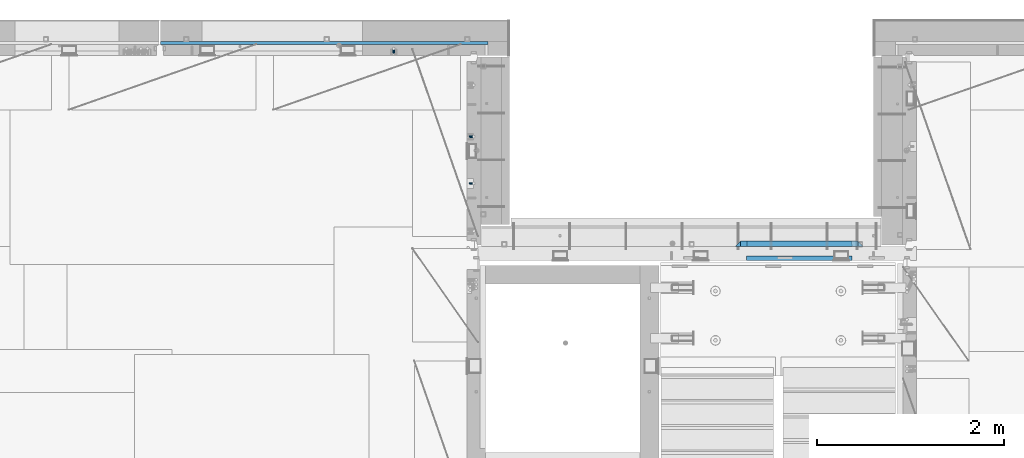
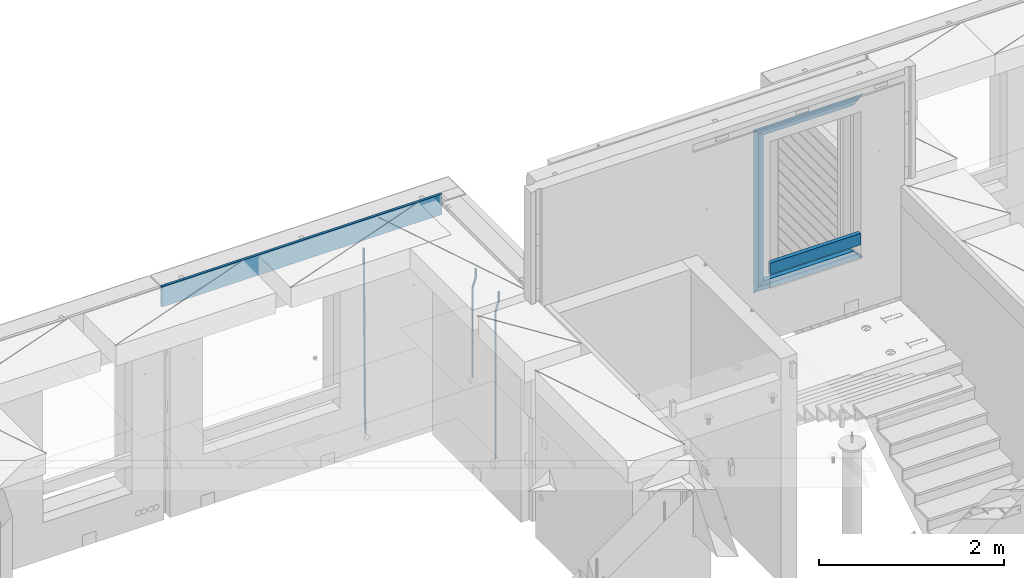
# One storey, part 118 of 341: 11 beams, 3 elements without a shape of their own.
"""IFC2X3 building model written with IfcOpenShell, lengths in millimetres."""

from ifc_helpers import new_model, si_unit, frame, origin_with_axes, place, context, subcontext, project, spatial, faceted_brep, material, type_object, element, aggregate, save


model = new_model("IFC2X3")

# Units and contexts
model_context = context("Model", 3, precision=1e-05, world=origin_with_axes())
body_context = subcontext(model_context, "Body", "Model", "MODEL_VIEW")
ifc_project = project(units=[si_unit("LENGTHUNIT", "METRE", prefix="MILLI"), si_unit("AREAUNIT", "SQUARE_METRE"), si_unit("VOLUMEUNIT", "CUBIC_METRE"), si_unit("MASSUNIT", "GRAM", prefix="KILO"), si_unit("TIMEUNIT", "SECOND"), si_unit("PLANEANGLEUNIT", "RADIAN"), si_unit("SOLIDANGLEUNIT", "STERADIAN"), si_unit("THERMODYNAMICTEMPERATUREUNIT", "DEGREE_CELSIUS"), si_unit("LUMINOUSINTENSITYUNIT", "LUMEN")], contexts=[model_context])

# Site, building, storey
site_placement = place(None, origin_with_axes())
site = spatial("IfcSite", under=ifc_project, at=site_placement, CompositionType="ELEMENT")
building_placement = place(site_placement, origin_with_axes())
building = spatial("IfcBuilding", under=site, at=building_placement, CompositionType="ELEMENT")
storey_placement = place(building_placement, origin_with_axes())
storey = spatial("IfcBuildingStorey", under=building, at=storey_placement, Name="5", CompositionType="ELEMENT", Elevation=0.0)

# Assembly, beam
assembly_1_placement = place(storey_placement, origin_with_axes())
assembly_1 = element("IfcElementAssembly", 1, at=assembly_1_placement, inside=storey, AssemblyPlace="NOTDEFINED", PredefinedType="REINFORCEMENT_UNIT")
ifc_material_1 = material()
beam_type_1 = type_object("IfcBeamType", Name="D20", PredefinedType="NOTDEFINED")
beam_1_placement = place(assembly_1_placement, frame((16830.0000000039, 22654.999995444, 93990.0), z_axis=(-0.000205762999925498, 0.999642804629538, -0.0267249099901004), x_axis=(4.30000201928125e-08, 0.0267249099948059, 0.999642825806181)))
beam_1 = element("IfcBeam", 2, at=beam_1_placement, type_object=beam_type_1, material=ifc_material_1, Name="JM20", ObjectType="D20", context=body_context, shape_type="Brep", body=[
    faceted_brep([(0.0, -10.0, 0.0), (-4.19531716033816e-08, -7.07106781186667, -7.07106781187031), (60.4266690400545, -7.0710677960451, -7.07106780570757), (60.4266690441291, -9.99999998418934, 6.15546014159918e-09), (0.0, 0.0, -10.0), (60.426669036824, 1.58106558956206e-08, -9.99999999384454), (4.196772351861e-08, 7.07106781186303, -7.07106781186667), (60.4266690363438, 7.07106782768096, -7.07106780570757), (0.0, 10.0, 0.0), (60.4266690388904, 10.0000000158179, 6.15182216279209e-09), (4.196772351861e-08, 7.07106781185939, 7.07106781185939), (60.4266690429649, 7.07106782768096, 7.07106781802577), (0.0, 0.0, 10.0), (60.4266690461809, 1.58179318532348e-08, 10.0000000061555), (-4.19531716033816e-08, -7.07106781187031, 7.07106781185939), (60.4266690466611, -7.07106779605238, 7.07106781802213), (61.0378400410118, -7.07106779588503, -7.07106780564936), (60.991799419251, -9.99999998403655, 6.21366780251265e-09), (61.0569027789461, 1.5985278878361e-08, -9.99999999378269), (61.0378209396877, 7.07106782784831, -7.07106780564936), (60.9917724058905, 10.0000000159635, 6.21366780251265e-09), (60.9457317841297, 7.07106782781193, 7.0710678180767), (60.9266690461809, 1.59488990902901e-08, 10.0000000062028), (60.9457508854539, -7.07106779591413, 7.0710678180767), (61.6489592143771, -7.07106614513759, -7.06310863441468), (61.5568818710308, -9.9999984576425, 0.00735959856683621), (61.6870830769039, 1.71821739058942e-06, -9.99179257185824), (61.6489210170112, 7.07106947854481, -7.06310888312146), (61.556827851804, 10.0000015422847, 0.00735924683976918), (61.4647505084577, 7.07106922979438, 7.07782747982128), (61.4266266459163, 1.36643211590126e-06, 10.0065114172685), (61.464788705809, -7.07106639389531, 7.07782772852806), (176.543135720174, -7.07075579406956, -5.56673531796696), (176.451058376813, -9.99968810657447, 1.50373291501455), (176.581259582701, 0.000312069292704109, -8.49541925541052), (176.543097522794, 7.07137982961285, -5.56673556667374), (176.451004357587, 10.00031189336, 1.50373256329476), (176.35892701424, 7.07137958085514, 8.57420079627263), (176.320803151699, 0.000311717507429421, 11.5028847337162), (176.358965211621, -7.07075604281999, 8.57420104497578), (177.098753836006, -7.07075429323595, -5.55949898843028), (176.98362511232, -9.99968666800123, 1.510669025065), (177.146421932586, 0.000313595905026887, -8.48805862247536), (177.098706077581, 7.07138133041735, -5.55949936166144), (176.983557571715, 10.0003133318824, 1.51066849724157), (176.868428848029, 7.07138095712435, 8.58083651073321), (176.820760751449, 0.000313067976094317, 11.5093961447819), (176.868476606425, -7.07075466652896, 8.58083688396073), (177.654312950661, -7.07075204110879, -5.54863964998367), (177.516135294456, -9.99968450931192, 1.52107783331303), (177.711524267797, 0.000315886711177882, -8.47701274570863), (177.654255632195, 7.07138358250813, -5.54864021007961), (177.516054233929, 10.0003154905207, 1.5210770412159), (177.377876577739, 7.0713830223176, 8.59079452451624), (177.320665260588, 0.000315094497636892, 11.5191676202448), (177.377933896176, -7.07075260129932, 8.59079508461218), (299.436796249574, -7.07025836271714, -3.1681962331204), (299.298618593355, -9.99919083092027, 3.90152125031091), (299.494007566798, 0.000809565110102994, -6.09656932889993), (299.436738931283, 7.07187726089978, -3.16819679320906), (299.298537533061, 10.0008091689197, 3.90152045822106), (299.160359876842, 7.07187670072017, 10.9712379416487), (299.103148559603, 0.000808772889286047, 13.8996110374392), (299.160417195119, -7.07025892290039, 10.9712385017483), (299.98743051647, -7.07025613056248, -3.15743315966392), (299.971788958996, -9.99918809853989, 3.91467979818117), (299.993912075952, 0.000811591617093654, -6.08679785393178), (299.987423933868, 7.07187949325817, -3.1574327280432), (299.971753863239, 10.0008119014747, 3.91467990454839), (299.95611230444, 7.07187992653053, 10.9867922621015), (299.949630744944, 0.000812204350950196, 13.9161569563694), (299.956118887014, -7.07025569729012, 10.9867918304735), (300.538107039494, -7.07025785017686, -3.16575821840888), (300.644985195438, -9.99919020432935, 3.90450175465594), (300.493854948218, 0.000810030429420294, -6.09435592770024), (300.538151196495, 7.071877773491, -3.16575855385963), (300.645047642858, 10.0008097955724, 3.90450128024895), (300.751925798773, 7.07187744142357, 10.9747612533101), (300.796177890064, 0.000809560813650023, 13.9033589625978), (300.751881641787, -7.07025818224065, 10.9747615887682), (2293.36490490142, -7.07648090940347, -33.2930642912361), (2293.47178305736, -10.0054132635523, -26.2228043181785), (2293.32065281013, -0.00541302880083094, -36.2216620005347), (2293.36494905842, 7.06565471425711, -33.2930646266868), (2293.47184550477, 9.99458673634581, -26.2228047925819), (2293.57872366071, 7.06565438219332, -19.1525448195243), (2293.62297575199, -0.00541349841296324, -16.2239471102366), (2293.57867950371, -7.0764812414709, -19.1525444840736), (2294.0658245362, -7.07648309818615, -33.3036607065333), (2294.05312277409, -10.0054150789219, -26.2315929392535), (2294.10928714235, -0.00541549149056664, -36.2335844756526), (2294.15805078732, 7.06565223761572, -33.3050546393533), (2294.18355038921, 9.99458451388637, -26.2335642579346), (2294.17084862708, 7.06565253314329, -19.1614964906439), (2294.12738602093, -0.00541507354500936, -16.2315727215355), (2294.07862237596, -7.07648280265857, -19.1601025578348), (2294.76670261032, -7.08562269121467, -33.294332712383), (2294.63442802057, -10.0129954178956, -26.2238563411993), (2294.89787471293, -0.0156988342423574, -36.2230891548279), (2294.95110548967, 7.05531064255774, -33.2944998654275), (2294.89521307347, 9.98530428734011, -26.2240927312887), (2294.76293848372, 7.0579315606592, -19.1536163601049), (2294.63176638114, -0.0119922963167483, -16.2248599176673), (2294.57853560438, -7.08300177311321, -19.1534492070678), (2316.52657204497, -7.36937582653991, -33.0047303660212), (2316.39429745522, -10.2967485532172, -25.9342539948302), (2316.65774414754, -0.299451969567599, -35.9334868084661), (2316.7109749243, 6.7715575072325, -33.0048975190657), (2316.65508250811, 9.70155115201487, -25.9344903849269), (2316.52280791836, 6.7741784253376, -18.8640140137468), (2316.39163581574, -0.295745431634714, -15.9352575713092), (2316.33840503903, -7.36675490843481, -18.863846860706), (2317.16202064224, -7.37766220584308, -32.9962731735213), (2317.05438744847, -10.3053562613532, -25.9254688497131), (2317.23607125619, -0.306993473008333, -35.925789846493), (2317.23316144495, 6.76474808850253, -32.9979477328052), (2317.15499573652, 9.6950321815566, -25.9278370341635), (2317.04736254275, 6.7673381260538, -18.8570327103698), (2316.97331192881, -0.303330606784584, -15.9275160373909), (2316.97622174003, -7.37507216829545, -18.8553581510787), (2317.79752306276, -7.37578610372293, -32.9880110666527), (2317.71453320107, -10.3033876998124, -25.9168792378296), (2317.81444760226, -0.305295583297266, -35.918287695793), (2317.75539265381, 6.76628640723357, -32.9911928173897), (2317.65495180529, 9.69652304524061, -25.9213789128698), (2317.5719619436, 6.76892144914746, -18.8502470840467), (2317.55503740412, -0.301569071270933, -15.9199704549137), (2317.61409235255, -7.3731510618054, -18.847065333317), (2417.8183084176, -7.07752398473531, -31.6906369377139), (2417.73531855589, -10.0051255808248, -24.6195051088798), (2417.83523295709, -0.007033464313281, -34.6209135668432), (2417.77617800863, 7.06454852621755, -31.6938186884508), (2417.67573716014, 9.99478516423187, -24.6240047839383), (2417.59274729842, 7.06718356813872, -17.5528729551006), (2417.57582275895, -0.00330695228694822, -14.6225963259749), (2417.6348777074, -7.07488894281778, -17.5496912043673)], [[[0, 1, 2, 3]], [[1, 4, 5, 2]], [[4, 6, 7, 5]], [[6, 8, 9, 7]], [[8, 10, 11, 9]], [[10, 12, 13, 11]], [[12, 14, 15, 13]], [[14, 0, 3, 15]], [[14, 12, 10, 8, 6, 4, 1, 0]], [[3, 2, 16, 17]], [[2, 5, 18, 16]], [[5, 7, 19, 18]], [[7, 9, 20, 19]], [[9, 11, 21, 20]], [[11, 13, 22, 21]], [[13, 15, 23, 22]], [[15, 3, 17, 23]], [[17, 16, 24, 25]], [[16, 18, 26, 24]], [[18, 19, 27, 26]], [[19, 20, 28, 27]], [[20, 21, 29, 28]], [[21, 22, 30, 29]], [[22, 23, 31, 30]], [[23, 17, 25, 31]], [[25, 24, 32, 33]], [[24, 26, 34, 32]], [[26, 27, 35, 34]], [[27, 28, 36, 35]], [[28, 29, 37, 36]], [[29, 30, 38, 37]], [[30, 31, 39, 38]], [[31, 25, 33, 39]], [[33, 32, 40, 41]], [[32, 34, 42, 40]], [[34, 35, 43, 42]], [[35, 36, 44, 43]], [[36, 37, 45, 44]], [[37, 38, 46, 45]], [[38, 39, 47, 46]], [[39, 33, 41, 47]], [[41, 40, 48, 49]], [[40, 42, 50, 48]], [[42, 43, 51, 50]], [[43, 44, 52, 51]], [[44, 45, 53, 52]], [[45, 46, 54, 53]], [[46, 47, 55, 54]], [[47, 41, 49, 55]], [[49, 48, 56, 57]], [[48, 50, 58, 56]], [[50, 51, 59, 58]], [[51, 52, 60, 59]], [[52, 53, 61, 60]], [[53, 54, 62, 61]], [[54, 55, 63, 62]], [[55, 49, 57, 63]], [[57, 56, 64, 65]], [[56, 58, 66, 64]], [[58, 59, 67, 66]], [[59, 60, 68, 67]], [[60, 61, 69, 68]], [[61, 62, 70, 69]], [[62, 63, 71, 70]], [[63, 57, 65, 71]], [[65, 64, 72, 73]], [[64, 66, 74, 72]], [[66, 67, 75, 74]], [[67, 68, 76, 75]], [[68, 69, 77, 76]], [[69, 70, 78, 77]], [[70, 71, 79, 78]], [[71, 65, 73, 79]], [[73, 72, 80, 81]], [[72, 74, 82, 80]], [[74, 75, 83, 82]], [[75, 76, 84, 83]], [[76, 77, 85, 84]], [[77, 78, 86, 85]], [[78, 79, 87, 86]], [[79, 73, 81, 87]], [[81, 80, 88, 89]], [[80, 82, 90, 88]], [[82, 83, 91, 90]], [[83, 84, 92, 91]], [[84, 85, 93, 92]], [[85, 86, 94, 93]], [[86, 87, 95, 94]], [[87, 81, 89, 95]], [[89, 88, 96, 97]], [[88, 90, 98, 96]], [[90, 91, 99, 98]], [[91, 92, 100, 99]], [[92, 93, 101, 100]], [[93, 94, 102, 101]], [[94, 95, 103, 102]], [[95, 89, 97, 103]], [[97, 96, 104, 105]], [[96, 98, 106, 104]], [[98, 99, 107, 106]], [[99, 100, 108, 107]], [[100, 101, 109, 108]], [[101, 102, 110, 109]], [[102, 103, 111, 110]], [[103, 97, 105, 111]], [[105, 104, 112, 113]], [[104, 106, 114, 112]], [[106, 107, 115, 114]], [[107, 108, 116, 115]], [[108, 109, 117, 116]], [[109, 110, 118, 117]], [[110, 111, 119, 118]], [[111, 105, 113, 119]], [[113, 112, 120, 121]], [[112, 114, 122, 120]], [[114, 115, 123, 122]], [[115, 116, 124, 123]], [[116, 117, 125, 124]], [[117, 118, 126, 125]], [[118, 119, 127, 126]], [[119, 113, 121, 127]], [[121, 120, 128, 129]], [[120, 122, 130, 128]], [[122, 123, 131, 130]], [[123, 124, 132, 131]], [[124, 125, 133, 132]], [[125, 126, 134, 133]], [[126, 127, 135, 134]], [[127, 121, 129, 135]], [[130, 131, 132, 133, 134, 135, 129, 128]]]),
])

# Assembly, beams
assembly_2_placement = place(storey_placement, origin_with_axes())
assembly_2 = element("IfcElementAssembly", 3, at=assembly_2_placement, inside=storey, AssemblyPlace="NOTDEFINED", PredefinedType="REINFORCEMENT_UNIT")
beam_2_placement = place(assembly_2_placement, frame((17685.0, 21755.0073333522, 96407.5), z_axis=(-0.999999913638316, 0.000415599999849952, 0.0), x_axis=(0.0, 0.0, -1.0)))
beam_2 = element("IfcBeam", 4, at=beam_2_placement, type_object=beam_type_1, material=ifc_material_1, Name="JM20", ObjectType="D20", context=body_context, shape_type="Brep", body=[
    faceted_brep([(0.0, -10.0, 0.0), (-4.19531716033816e-08, -7.07106781186667, -7.07106781187031), (113.248091332178, -7.0710684840451, -7.0710678117357), (113.248091314759, -10.0000006713562, -2.51020537689328e-10), (0.0, 0.0, -10.0), (113.248091374131, -6.72178430249915e-07, -9.99999999986903), (4.196772351861e-08, 7.07106781186303, -7.07106781186667), (113.248091416113, 7.07106713968824, -7.07106781173934), (0.0, 10.0, 0.0), (113.248091433488, 9.99999932782521, 1.30967237055302e-10), (4.196772351861e-08, 7.07106781185939, 7.07106781185939), (113.248091416113, 7.0710671396846, 7.071067811994), (0.0, 0.0, 10.0), (113.248091374131, -6.72174792271107e-07, 10.0000000001273), (-4.19531716033816e-08, -7.07106781187031, 7.07106781185939), (113.248091332178, -7.0710684840451, 7.071067811994), (130.699843527167, -7.06993249763036, -4.33745683788584), (128.538066582521, -9.99900540317321, 2.39499413731755), (131.594536475241, 0.00119355250353692, -7.12624594330919), (130.698046432328, 7.07220300913468, -4.33773834422391), (128.535525107087, 10.0009944322555, 2.39459602660281), (126.373748162892, 7.07192152754578, 9.1270470011732), (125.479055214906, 0.000795477419160306, 11.9158361066184), (126.37554525779, -7.07021397921199, 9.12732850753673), (240.336258550378, -7.05529970173666, 30.8729495437874), (238.174481606227, -9.98437260450009, 37.6054005176375), (241.230951498423, 0.0158263482953771, 28.0841604381058), (240.334461455612, 7.0868358050102, 30.8726680369582), (238.171940130502, 10.0156272283348, 37.6050024077231), (236.010163186409, 7.08655432384694, 44.3374533824244), (235.115470238379, 0.0154282738185429, 47.1262424881097), (236.011960281176, -7.05558118289991, 44.3377348892536), (253.461915329972, -7.05444528127919, 32.9289287376414), (253.46191532613, -9.98337746617108, 39.9999965521893), (253.461915339081, 0.0166225284556276, 29.9999965443676), (253.461915348205, 7.08769034247234, 32.9289287273205), (253.461915352003, 10.0166225357716, 39.9999965370152), (253.461915348293, 7.08769035281148, 47.0710643509774), (253.461915339183, 0.0166225430875784, 49.999996544273), (253.46191533003, -7.05444527093641, 47.0710643613093), (1417.49999998364, -7.05444797759628, 32.9289287358552), (1417.49999997689, -9.98338016170965, 39.9999965493844), (1417.49999999996, 0.0166198326005542, 29.9999965436982), (1417.50000001628, 7.08768764613342, 32.9289287278079), (1417.50000002306, 10.0166198382904, 39.9999965380084), (1417.5000000163, 7.08768765417699, 47.0710643515376), (1417.49999999999, 0.0166198439801519, 49.9999965436946), (1417.49999998366, -7.05444796955271, 47.0710643595849)], [[[0, 1, 2, 3]], [[1, 4, 5, 2]], [[4, 6, 7, 5]], [[6, 8, 9, 7]], [[8, 10, 11, 9]], [[10, 12, 13, 11]], [[12, 14, 15, 13]], [[14, 0, 3, 15]], [[14, 12, 10, 8, 6, 4, 1, 0]], [[3, 2, 16, 17]], [[2, 5, 18, 16]], [[5, 7, 19, 18]], [[7, 9, 20, 19]], [[9, 11, 21, 20]], [[11, 13, 22, 21]], [[13, 15, 23, 22]], [[15, 3, 17, 23]], [[17, 16, 24, 25]], [[16, 18, 26, 24]], [[18, 19, 27, 26]], [[19, 20, 28, 27]], [[20, 21, 29, 28]], [[21, 22, 30, 29]], [[22, 23, 31, 30]], [[23, 17, 25, 31]], [[25, 24, 32, 33]], [[24, 26, 34, 32]], [[26, 27, 35, 34]], [[27, 28, 36, 35]], [[28, 29, 37, 36]], [[29, 30, 38, 37]], [[30, 31, 39, 38]], [[31, 25, 33, 39]], [[33, 32, 40, 41]], [[32, 34, 42, 40]], [[34, 35, 43, 42]], [[35, 36, 44, 43]], [[36, 37, 45, 44]], [[37, 38, 46, 45]], [[38, 39, 47, 46]], [[39, 33, 41, 47]], [[42, 43, 44, 45, 46, 47, 41, 40]]]),
])
beam_type_2 = type_object("IfcBeamType", Name="D25", PredefinedType="NOTDEFINED")
beam_3_placement = place(assembly_2_placement, frame((17685.0, 21255.0073333522, 96407.5), z_axis=(-0.999999913638316, 0.000415599999849952, 0.0), x_axis=(0.0, 0.0, -1.0)))
beam_3 = element("IfcBeam", 5, at=beam_3_placement, type_object=beam_type_2, material=ifc_material_1, Name="JM25", ObjectType="D25", context=body_context, shape_type="Brep", body=[
    faceted_brep([(-7.41420080885291e-08, -12.5, -3.63797880709171e-12), (-6.42030499875546e-08, -10.8253175473074, -6.25000000000364), (113.248091310059, -10.8253182190492, -6.25000000001091), (113.248091299931, -12.5000006708469, -2.80124368146062e-10), (-3.70782800018787e-08, -6.25000000000364, -10.8253175473074), (113.248091337184, -6.25000067174187, -10.8253175473183), (-1.45519152283669e-11, -3.63797880709171e-12, -12.5), (113.248091374247, -6.71741872793064e-07, -12.5000000000109), (3.70637280866504e-08, 6.25, -10.8253175473074), (113.248091411326, 6.24999932825813, -10.8253175473183), (6.42030499875546e-08, 10.8253175473001, -6.25000000000364), (113.248091438465, 10.8253168755618, -6.25000000001091), (7.41420080885291e-08, 12.4999999999927, 0.0), (113.248091448404, 12.4999993282545, -1.09139364212751e-11), (6.42176019027829e-08, 10.8253175473001, 6.24999999999636), (113.24809143848, 10.8253168755618, 6.24999999998545), (3.70928319171071e-08, 6.24999999999636, 10.8253175473037), (113.248091411355, 6.24999932825449, 10.8253175472928), (1.45519152283669e-11, -3.63797880709171e-12, 12.4999999999964), (113.248091374277, -6.71741872793064e-07, 12.4999999999854), (-3.7049176171422e-08, -6.25000000000364, 10.8253175473001), (113.248091337213, -6.25000067174187, 10.8253175472928), (-6.41884980723262e-08, -10.8253175473074, 6.25), (113.248091310074, -10.8253182190492, 6.24999999998909), (130.449259230882, -10.8241986432586, -3.55564009493173), (128.538384125903, -12.4990054706068, 2.39504387892885), (131.847691315706, -6.24879007587151, -7.91190976778307), (132.358971633032, 0.00124320192480809, -9.50650619965018), (131.846103034666, 6.25120982069348, -7.91215856435883), (130.446508247391, 10.826436272193, -3.55607102324211), (128.535207564215, 12.5009943235709, 2.39454628487874), (126.624332459658, 10.8261874972886, 8.34523025788076), (125.225900374833, 6.25077892990521, 12.7014999307248), (124.714620057581, 0.000745652105251793, 14.2960963626065), (125.227488655888, -6.24922096664886, 12.7017487273151), (126.62708344312, -10.8244474181665, 8.3456611861875), (240.085674248156, -10.8095671496994, 31.6547662857156), (238.174799143511, -12.4843739739517, 37.6054502584157), (241.484106332937, -6.23415858247972, 27.2984966126423), (241.995386650233, 0.0158746952838555, 25.703900180506), (241.482518051911, 6.26584131414347, 27.2982478155536), (240.082923264708, 10.8410677658503, 31.6543353565175), (238.171622581605, 12.5156258174902, 37.6049526646493), (236.260747477107, 10.8408189914335, 43.5556366377568), (234.862315392325, 6.26541042421377, 47.9119063108337), (234.351035075029, 0.0153771464501915, 49.5065027429664), (234.863903673351, -6.23458947240579, 47.9121551079224), (236.263498460554, -10.8098159241163, 43.5560675669512), (253.461915305525, -10.8086965039183, 33.7499965486895), (253.461915300941, -12.4833789551158, 39.9999965501447), (253.461915317355, -6.23337895905206, 29.1746789989811), (253.461915333464, 0.0166210400311684, 27.4999965429452), (253.461915349588, 6.26662104088609, 29.1746789923018), (253.461915361389, 10.8419385905909, 33.7499965371353), (253.461915365653, 12.5166210465904, 39.9999965362076), (253.461915361288, 10.8419385972084, 46.2499965370662), (253.461915349428, 6.26662105234573, 50.8253140867819), (253.461915333304, 0.0166210532552213, 52.4999965428069), (253.461915317152, -6.23337894759607, 50.8253140934612), (253.461915305408, -10.8086964973008, 46.2499965486277), (2197.49999997206, -10.8087015173915, 33.749996548926), (2197.49999996777, -12.4833839668026, 39.9999965498064), (2197.49999998385, -6.23338397248881, 29.1746789992176), (2197.49999999997, 0.0166160266307998, 27.4999965432398), (2197.50000001608, 6.26661602751119, 29.1746789926474), (2197.5000000279, 10.8419335772196, 33.74999653755), (2197.5000000322, 12.5166160331937, 39.9999965366696), (2197.50000002791, 10.8419335837862, 46.2499965375537), (2197.50000001611, 6.26661603888351, 50.8253140872584), (2197.5, 0.0166160397602653, 52.4999965432398), (2197.49999998388, -6.23338396111649, 50.825314093825), (2197.49999997209, -10.8087015108249, 46.2499965489224)], [[[0, 1, 2, 3]], [[1, 4, 5, 2]], [[4, 6, 7, 5]], [[6, 8, 9, 7]], [[8, 10, 11, 9]], [[10, 12, 13, 11]], [[12, 14, 15, 13]], [[14, 16, 17, 15]], [[16, 18, 19, 17]], [[18, 20, 21, 19]], [[20, 22, 23, 21]], [[22, 0, 3, 23]], [[22, 20, 18, 16, 14, 12, 10, 8, 6, 4, 1, 0]], [[3, 2, 24, 25]], [[2, 5, 26, 24]], [[5, 7, 27, 26]], [[7, 9, 28, 27]], [[9, 11, 29, 28]], [[11, 13, 30, 29]], [[13, 15, 31, 30]], [[15, 17, 32, 31]], [[17, 19, 33, 32]], [[19, 21, 34, 33]], [[21, 23, 35, 34]], [[23, 3, 25, 35]], [[25, 24, 36, 37]], [[24, 26, 38, 36]], [[26, 27, 39, 38]], [[27, 28, 40, 39]], [[28, 29, 41, 40]], [[29, 30, 42, 41]], [[30, 31, 43, 42]], [[31, 32, 44, 43]], [[32, 33, 45, 44]], [[33, 34, 46, 45]], [[34, 35, 47, 46]], [[35, 25, 37, 47]], [[37, 36, 48, 49]], [[36, 38, 50, 48]], [[38, 39, 51, 50]], [[39, 40, 52, 51]], [[40, 41, 53, 52]], [[41, 42, 54, 53]], [[42, 43, 55, 54]], [[43, 44, 56, 55]], [[44, 45, 57, 56]], [[45, 46, 58, 57]], [[46, 47, 59, 58]], [[47, 37, 49, 59]], [[49, 48, 60, 61]], [[48, 50, 62, 60]], [[50, 51, 63, 62]], [[51, 52, 64, 63]], [[52, 53, 65, 64]], [[53, 54, 66, 65]], [[54, 55, 67, 66]], [[55, 56, 68, 67]], [[56, 57, 69, 68]], [[57, 58, 70, 69]], [[58, 59, 71, 70]], [[59, 49, 61, 71]], [[62, 63, 64, 65, 66, 67, 68, 69, 70, 71, 61, 60]]]),
])
aggregate(assembly_2, [beam_3, beam_2])

assembly_3_placement = place(storey_placement, origin_with_axes())
assembly_3 = element("IfcElementAssembly", 6, at=assembly_3_placement, inside=storey, AssemblyPlace="NOTDEFINED", PredefinedType="REINFORCEMENT_UNIT")
ifc_material_2 = material(Name="TIMBER/T24")
beam_type_3 = type_object("IfcBeamType", PredefinedType="NOTDEFINED")
beam_4_placement = place(assembly_3_placement, frame((21724.9984049797, 20455.0, 96185.0), z_axis=(0.0, 0.0, 1.0), x_axis=(-1.0, 3.00000001838171e-08, 0.0)))
beam_4 = element("IfcBeam", 7, at=beam_4_placement, type_object=beam_type_3, material=ifc_material_2, context=body_context, shape_type="Brep", body=[
    faceted_brep([(-3.63797880709171e-12, 24.9999999999964, -75.0), (-3.63797880709171e-12, 24.9999999999964, 75.0), (1130.0, 25.0, 75.0), (1130.0, 25.0, -75.0), (0.0, -25.0000000000073, 75.0), (1130.0, -25.0, 75.0), (0.0, -25.0000000000073, -75.0), (1130.0, -25.0, -75.0)], [[[0, 1, 2, 3]], [[1, 4, 5, 2]], [[4, 6, 7, 5]], [[6, 0, 3, 7]], [[5, 7, 3, 2]], [[6, 4, 1, 0]]]),
])
ifc_material_3 = material(Name="CONCRETE/C25/30")
beam_type_4 = type_object("IfcBeamType", PredefinedType="NOTDEFINED")
beam_5_placement = place(assembly_3_placement, frame((21844.9984049797, 20610.0000000447, 97945.0), z_axis=(0.0, 0.0, -1.0), x_axis=(-1.0, 3.00000001838171e-08, 0.0)))
beam_5 = element("IfcBeam", 8, at=beam_5_placement, type_object=beam_type_4, material=ifc_material_3, context=body_context, shape_type="Brep", body=[
    faceted_brep([(1310.0, -30.0, 30.0), (60.0000000000073, -30.0, 30.0), (0.0, -30.0, -30.0), (1370.0, -30.0, -30.0), (1310.0, 30.0, 30.0), (60.0000000000073, 30.0, 30.0)], [[[0, 1, 2, 3]], [[0, 3, 4]], [[1, 0, 4, 5]], [[5, 2, 1]], [[4, 3, 2, 5]]]),
])
beam_6_placement = place(assembly_3_placement, frame((21784.9984049797, 20609.9999988829, 97885.0), z_axis=(0.0, 0.0, -1.0), x_axis=(-1.0, 3.00000001838171e-08, 0.0)))
beam_6 = element("IfcBeam", 9, at=beam_6_placement, type_object=beam_type_4, material=ifc_material_3, context=body_context, shape_type="Brep", body=[
    faceted_brep([(0.0, -30.0, -30.0), (64.0540540540533, -30.0, 24.9034748914419), (65.6756756756768, 30.0, 26.293436281092), (0.0, 30.0, -30.0), (64.0540540540533, -30.0, 24.0540540540533), (65.6756756756768, 30.0, 25.6756756756804), (1185.94594588314, -29.9999988381387, 24.0540541168593), (1184.32432432432, 29.9999988381387, 25.6756756756804), (1184.32432432432, 29.9999988381387, 26.2934362810629), (1250.0, 29.9999988381387, -30.0), (1250.0, -29.9999988381387, -30.0), (1185.94594588314, -29.9999988381387, 24.9034749452549)], [[[0, 1, 2, 3]], [[4, 5, 2, 1]], [[6, 7, 5, 4]], [[3, 2, 5, 7, 8, 9]], [[0, 3, 9, 10]], [[6, 4, 1, 0, 10, 11]], [[7, 6, 11, 8]], [[10, 9, 8, 11]]]),
])
beam_7_placement = place(assembly_3_placement, frame((20504.9984049797, 20610.0000000447, 97975.0), z_axis=(1.0, 0.0, 0.0), x_axis=(0.0, 0.0, -1.0)))
beam_7 = element("IfcBeam", 10, at=beam_7_placement, type_object=beam_type_4, material=ifc_material_3, context=body_context, shape_type="Brep", body=[
    faceted_brep([(60.0000000000073, 30.0, 30.0), (0.0, -30.0, -30.0), (60.0000000000073, -30.0, 30.0), (2095.00000000001, -30.0, 30.0), (2155.0, -30.0, -30.0), (2095.00000000001, 30.0, 30.0)], [[[0, 1, 2]], [[3, 2, 1, 4]], [[3, 4, 5]], [[2, 3, 5, 0]], [[4, 1, 0, 5]]]),
])
beam_8_placement = place(assembly_3_placement, frame((20534.9984049797, 20609.9999988829, 95910.0), z_axis=(0.0, 0.0, 1.0), x_axis=(1.0, 0.0, 0.0)))
beam_8 = element("IfcBeam", 11, at=beam_8_placement, type_object=beam_type_4, material=ifc_material_3, context=body_context, shape_type="Brep", body=[
    faceted_brep([(1185.94594588314, -29.9999988381387, 24.0540541168593), (1184.32432432432, 29.9999988381387, 25.6756756756804), (65.6756756756768, 30.0, 25.6756756756804), (64.0540540540533, -30.0, 24.0540540540533), (65.6756756756768, 30.0, 26.293436281092), (64.0540540540533, -30.0, 24.9034748914419), (0.0, -30.0, -30.0), (0.0, 30.0, -30.0), (1250.0, 29.9999988381387, -30.0), (1250.0, -29.9999988381387, -30.0), (1185.94594588314, -29.9999988381387, 24.9034749452549), (1184.32432432432, 29.9999988381387, 26.2934362810629)], [[[0, 1, 2, 3]], [[3, 2, 4, 5]], [[6, 5, 4, 7]], [[6, 7, 8, 9]], [[0, 3, 5, 6, 9, 10]], [[1, 0, 10, 11]], [[7, 4, 2, 1, 11, 8]], [[9, 8, 11, 10]]]),
])
beam_9_placement = place(assembly_3_placement, frame((20474.9984049797, 20610.0000000447, 95850.0), z_axis=(0.0, 0.0, 1.0), x_axis=(1.0, 0.0, 0.0)))
beam_9 = element("IfcBeam", 12, at=beam_9_placement, type_object=beam_type_4, material=ifc_material_3, context=body_context, shape_type="Brep", body=[
    faceted_brep([(60.0000000000073, 30.0, 30.0), (0.0, -30.0, -30.0), (60.0000000000073, -30.0, 30.0), (1310.0, -30.0, 30.0), (1370.0, -30.0, -30.0), (1310.0, 30.0, 30.0)], [[[0, 1, 2]], [[3, 2, 1, 4]], [[2, 3, 5, 0]], [[5, 4, 1, 0]], [[3, 4, 5]]]),
])
beam_type_5 = type_object("IfcBeamType", PredefinedType="NOTDEFINED")
beam_10_placement = place(assembly_3_placement, frame((20569.9984049797, 20609.9999988829, 97915.0), z_axis=(1.0, 0.0, 0.0), x_axis=(0.0, 0.0, -1.0)))
beam_10 = element("IfcBeam", 13, at=beam_10_placement, type_object=beam_type_5, material=ifc_material_3, context=body_context, shape_type="Brep", body=[
    faceted_brep([(2035.0, -29.9999988381387, -35.0), (2035.0, 29.9999988381387, -35.0), (1978.70656371892, 29.9999988381387, 30.6756756756731), (1980.09652505475, -29.9999988381387, 29.0540541168557), (56.2934362811066, 30.0, 30.6756756756768), (54.9034748914273, -30.0, 29.0540540540533), (0.0, -30.0, -35.0), (0.0, 30.0, -35.0)], [[[0, 1, 2, 3]], [[3, 2, 4, 5]], [[0, 3, 5, 6]], [[1, 0, 6, 7]], [[2, 1, 7, 4]], [[6, 5, 4, 7]]]),
])
aggregate(assembly_3, [beam_5, beam_6, beam_7, beam_10, beam_8, beam_9, beam_4])

# Beam
beam_type_6 = type_object("IfcBeamType", Name="270X30", PredefinedType="NOTDEFINED")
beam_11_placement = place(assembly_1_placement, frame((17835.0, 22755.0, 96605.0), z_axis=(0.0, 0.0, 1.0), x_axis=(-1.0, 3.00000001838171e-08, 0.0)))
beam_11 = element("IfcBeam", 14, at=beam_11_placement, type_object=beam_type_6, material=ifc_material_3, ObjectType="270X30", context=body_context, shape_type="Brep", body=[
    faceted_brep([(0.0, 15.0, -135.0), (0.0, 15.0, 135.0), (3495.00000000002, 15.0, 135.0), (3495.00000000002, 15.0, -135.0), (0.0, -15.0, 135.0), (3495.00000000002, -15.0, 135.0), (0.0, -15.0, -135.0), (3495.00000000002, -15.0, -135.0)], [[[0, 1, 2, 3]], [[1, 4, 5, 2]], [[4, 6, 7, 5]], [[6, 0, 3, 7]], [[5, 7, 3, 2]], [[6, 4, 1, 0]]]),
])

aggregate(assembly_1, [beam_1, beam_11])

save(model, "model.ifc")
